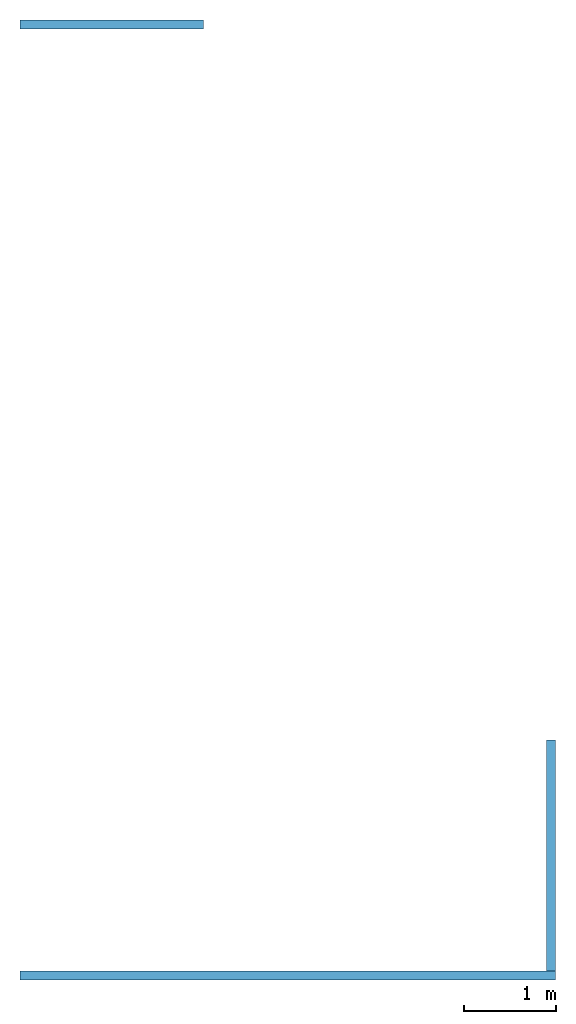
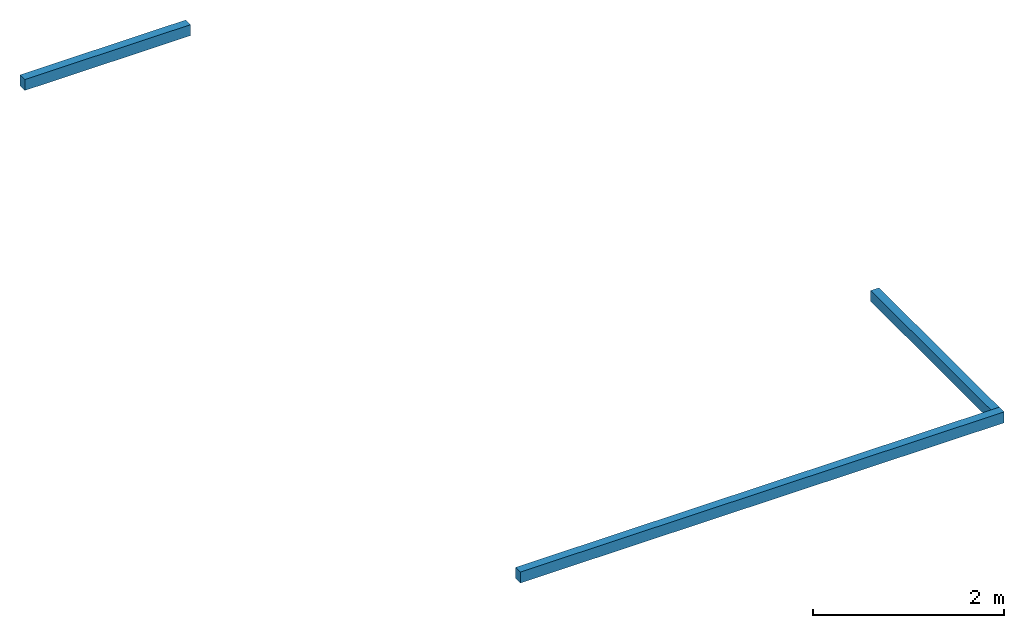
# One storey: 3 walls.
"""IFC2X3 building model written with IfcOpenShell, lengths in millimetres."""

from ifc_helpers import new_model, entity, si_unit, converted_unit, derived_unit, direction, frame, frame_2d, origin, place, context, subcontext, project, spatial, rectangle, extrude, material, layer, layer_set, layer_usage, type_object, element, save


model = new_model("IFC2X3")

# Units and contexts
model_context = context("Model", 3, precision=0.01, world=origin(), true_north=direction((6.12303176911189e-17, 1.0)))
body_context = subcontext(model_context, "Body", "Model", "MODEL_VIEW")
ifc_project = project(units=[si_unit("LENGTHUNIT", "METRE", prefix="MILLI"), si_unit("AREAUNIT", "SQUARE_METRE"), si_unit("VOLUMEUNIT", "CUBIC_METRE"), converted_unit("PLANEANGLEUNIT", "DEGREE", entity("IfcRatioMeasure", 0.0174532925199433), si_unit("PLANEANGLEUNIT", "RADIAN"), dimensions=[0, 0, 0, 0, 0, 0, 0]), si_unit("MASSUNIT", "GRAM", prefix="KILO"), derived_unit("MASSDENSITYUNIT", [(si_unit("MASSUNIT", "GRAM", prefix="KILO"), 1), (si_unit("LENGTHUNIT", "METRE"), -3)]), si_unit("TIMEUNIT", "SECOND"), si_unit("FREQUENCYUNIT", "HERTZ"), si_unit("THERMODYNAMICTEMPERATUREUNIT", "DEGREE_CELSIUS"), derived_unit("THERMALTRANSMITTANCEUNIT", [(si_unit("MASSUNIT", "GRAM", prefix="KILO"), 1), (si_unit("THERMODYNAMICTEMPERATUREUNIT", "KELVIN"), -1), (si_unit("TIMEUNIT", "SECOND"), -3)]), derived_unit("VOLUMETRICFLOWRATEUNIT", [(si_unit("LENGTHUNIT", "METRE"), 3), (si_unit("TIMEUNIT", "SECOND"), -1)]), si_unit("ELECTRICCURRENTUNIT", "AMPERE"), si_unit("ELECTRICVOLTAGEUNIT", "VOLT"), si_unit("POWERUNIT", "WATT"), si_unit("FORCEUNIT", "NEWTON", prefix="KILO"), si_unit("ILLUMINANCEUNIT", "LUX"), si_unit("LUMINOUSFLUXUNIT", "LUMEN"), si_unit("LUMINOUSINTENSITYUNIT", "CANDELA"), derived_unit("USERDEFINED", [(si_unit("MASSUNIT", "GRAM", prefix="KILO"), -1), (si_unit("LENGTHUNIT", "METRE"), -2), (si_unit("TIMEUNIT", "SECOND"), 3), (si_unit("LUMINOUSFLUXUNIT", "LUMEN"), 1)]), derived_unit("LINEARVELOCITYUNIT", [(si_unit("LENGTHUNIT", "METRE"), 1), (si_unit("TIMEUNIT", "SECOND"), -1)]), si_unit("PRESSUREUNIT", "PASCAL"), derived_unit("USERDEFINED", [(si_unit("LENGTHUNIT", "METRE"), -2), (si_unit("MASSUNIT", "GRAM", prefix="KILO"), 1), (si_unit("TIMEUNIT", "SECOND"), -2)])], contexts=[model_context])

# Site, building, storey
site_placement = place(None, origin())
site = spatial("IfcSite", under=ifc_project, at=site_placement, CompositionType="ELEMENT")
building_placement = place(site_placement, origin())
building = spatial("IfcBuilding", under=site, at=building_placement, CompositionType="ELEMENT")
storey_placement = place(building_placement, origin())
storey = spatial("IfcBuildingStorey", under=building, at=storey_placement, Name="00 Ground level", CompositionType="ELEMENT", Elevation=0.0)

# Walls
ifc_material_1 = material(Name="04_XPS PLUS 30 SF")
ifc_layer_1 = layer(ifc_material_1, 50.0)
ifc_material_2 = material(Name="02_C40/55")
ifc_layer_2 = layer(ifc_material_2, 50.0)
ifc_layer_set = layer_set([ifc_layer_1, ifc_layer_2], Name="Basic Wall:00_beton fall")
ifc_layer_usage_1 = layer_usage(ifc_layer_set, "AXIS2", "NEGATIVE", 50.0)
wall_type = type_object("IfcWallType", Name="Basic Wall:00_beton fall", PredefinedType="STANDARD", material=ifc_layer_set)
wall_1_placement = place(storey_placement, frame((34783.4900708518, -74125.8241905963, -140.0), z_axis=(0.0, 0.0, 1.0), x_axis=(-1.0, 0.0, 0.0)))
element("IfcWallStandardCase", 1, at=wall_1_placement, inside=storey, type_object=wall_type, material=ifc_layer_usage_1, Name="Basic Wall:00_beton fall", ObjectType="Basic Wall:00_beton fall", context=body_context, shape_type="SweptSolid", body=[
    extrude(rectangle(XDim=5839.99999999999, YDim=99.9999999999946, at=frame_2d((2919.99999999999, 2.34479102800833e-13), x_axis=(-1.0, 0.0))), origin(), (0.0, 0.0, 1.0), 140.0),
])
ifc_layer_usage_2 = layer_usage(ifc_layer_set, "AXIS2", "NEGATIVE", 50.0)
wall_2_placement = place(storey_placement, frame((34733.4900708518, -71560.8241905963, -140.0), z_axis=(0.0, 0.0, 1.0), x_axis=(0.0, -1.0, 0.0)))
element("IfcWallStandardCase", 2, at=wall_2_placement, inside=storey, type_object=wall_type, material=ifc_layer_usage_2, Name="Basic Wall:00_beton fall", ObjectType="Basic Wall:00_beton fall", context=body_context, shape_type="SweptSolid", body=[
    extrude(rectangle(XDim=2514.99999999998, YDim=100.000000000003, at=frame_2d((1257.49999999999, 0.0), x_axis=(-1.0, 0.0))), origin(), (0.0, 0.0, 1.0), 140.0),
])
ifc_layer_usage_3 = layer_usage(ifc_layer_set, "AXIS2", "NEGATIVE", 50.0)
wall_3_placement = place(storey_placement, frame((28943.4900708518, -63755.8241905963, -140.0)))
element("IfcWallStandardCase", 3, at=wall_3_placement, inside=storey, type_object=wall_type, material=ifc_layer_usage_3, Name="Basic Wall:00_beton fall", ObjectType="Basic Wall:00_beton fall", context=body_context, shape_type="SweptSolid", body=[
    extrude(rectangle(XDim=2000.00000000001, YDim=99.9999999999946, at=frame_2d((1000.00000000001, 2.8350655156828e-12), x_axis=(-1.0, 0.0))), origin(), (0.0, 0.0, 1.0), 140.0),
])

save(model, "model.ifc")
